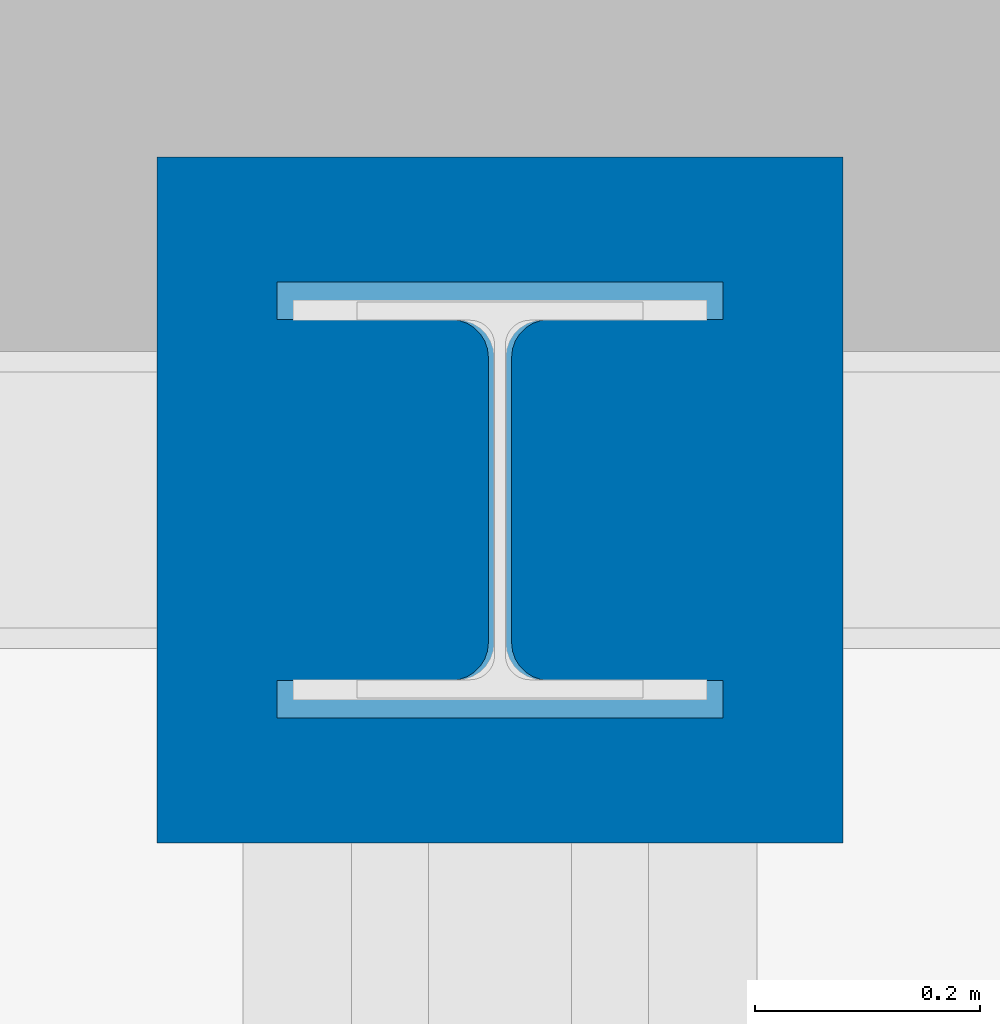
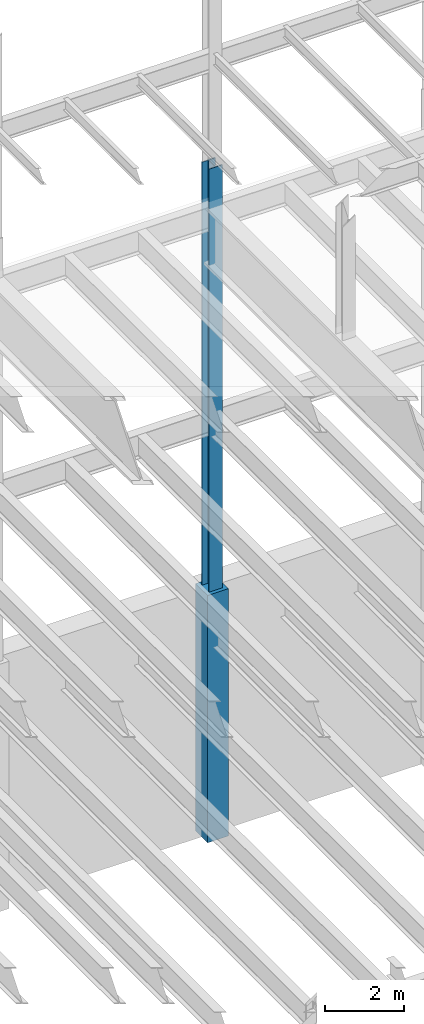
# One storey, part 61 of 150: 2 columns.
"""IFC2X3 building model written with IfcOpenShell, lengths in millimetres."""

from ifc_helpers import new_model, si_unit, frame, origin_with_axes, origin_2d_with_axis, place, context, subcontext, project, spatial, rectangle, i_section, extrude, material, type_object, element, save


model = new_model("IFC2X3")

# Units and contexts
model_context = context("Model", 3, precision=1e-05, world=origin_with_axes())
body_context = subcontext(model_context, "Body", "Model", "MODEL_VIEW")
ifc_project = project(units=[si_unit("LENGTHUNIT", "METRE", prefix="MILLI"), si_unit("AREAUNIT", "SQUARE_METRE"), si_unit("VOLUMEUNIT", "CUBIC_METRE"), si_unit("MASSUNIT", "GRAM", prefix="KILO"), si_unit("TIMEUNIT", "SECOND"), si_unit("PLANEANGLEUNIT", "RADIAN"), si_unit("SOLIDANGLEUNIT", "STERADIAN"), si_unit("THERMODYNAMICTEMPERATUREUNIT", "DEGREE_CELSIUS"), si_unit("LUMINOUSINTENSITYUNIT", "LUMEN")], contexts=[model_context])

# Site, building, storey
site_placement = place(None, origin_with_axes())
site = spatial("IfcSite", under=ifc_project, at=site_placement, CompositionType="ELEMENT")
building_placement = place(site_placement, origin_with_axes())
building = spatial("IfcBuilding", under=site, at=building_placement, Name="Undefined", CompositionType="ELEMENT")
storey_placement = place(building_placement, origin_with_axes())
storey = spatial("IfcBuildingStorey", under=building, at=storey_placement, Name="Undefined", CompositionType="ELEMENT", Elevation=0.0)

# Columns
ifc_material_1 = material(Name="STEEL/A992")
column_type_1 = type_object("IfcColumnType", Name="W14X176", PredefinedType="NOTDEFINED")
column_1_placement = place(storey_placement, frame((24587.2, 38862.0, 22707.6), z_axis=(0.0, 0.0, 1.0), x_axis=(1.0, 0.0, 0.0)))
element("IfcColumn", 1, at=column_1_placement, inside=storey, type_object=column_type_1, material=ifc_material_1, Name="COLUMN", ObjectType="W14X176", context=body_context, shape_type="SweptSolid", body=[
    extrude(i_section(OverallWidth=396.875, OverallDepth=387.35, WebThickness=20.6375, FlangeThickness=33.274, FilletRadius=33.401, at=origin_2d_with_axis()), frame((0.0, 0.0, 14097.0012877801), z_axis=(0.0, 0.0, -1.0), x_axis=(-1.0, 0.0, 0.0)), (0.0, 0.0, 1.0), 14097.0012877801),
])
ifc_material_2 = material(Name="CONCRETE/5000")
column_type_2 = type_object("IfcColumnType", PredefinedType="NOTDEFINED")
column_2_placement = place(storey_placement, frame((24587.2, 38862.0, 16154.4), z_axis=(0.0, 0.0, 1.0), x_axis=(1.0, 0.0, 0.0)))
element("IfcColumn", 2, at=column_2_placement, inside=storey, type_object=column_type_2, material=ifc_material_2, Name="COLUMN", context=body_context, shape_type="SweptSolid", body=[
    extrude(rectangle(XDim=609.6, YDim=609.6, at=origin_2d_with_axis()), frame((0.0, 0.0, 7620.0), z_axis=(0.0, 0.0, -1.0), x_axis=(0.0, -1.0, 0.0)), (0.0, 0.0, 1.0), 7620.0),
])

save(model, "model.ifc")
